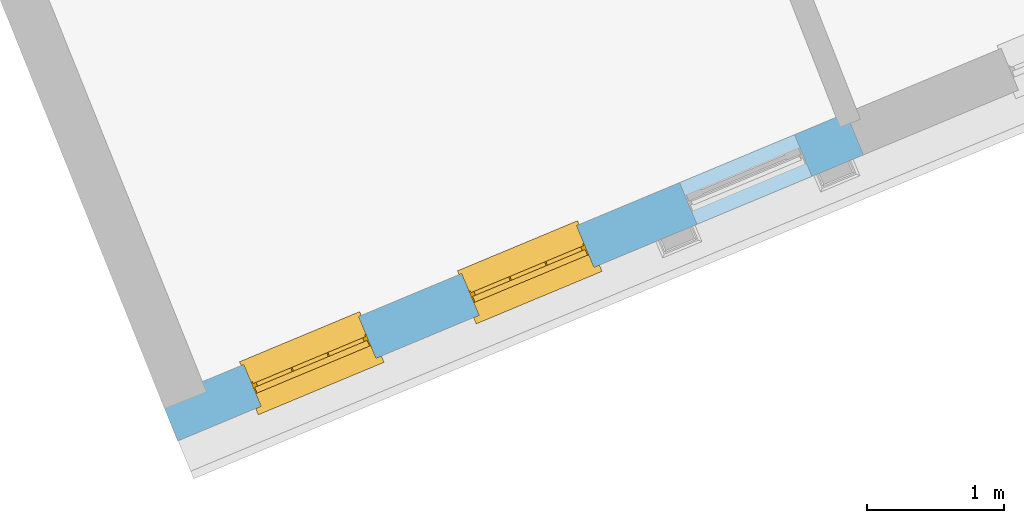
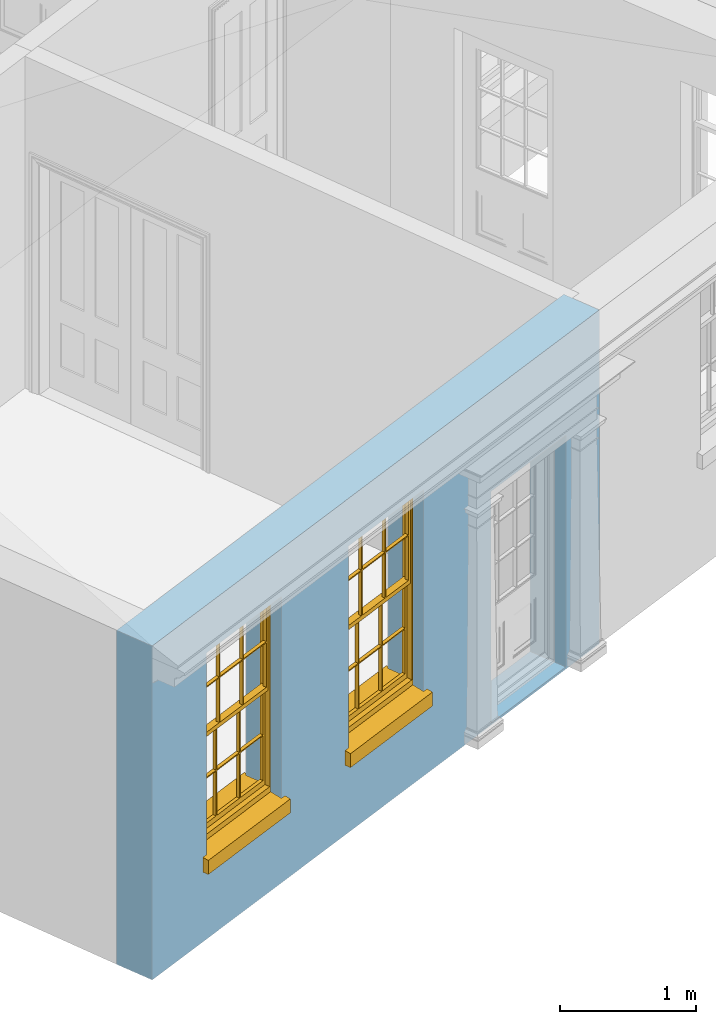
# One storey, part 3 of 19: 2 windows, 3 openings, plus 1 element that does not belong to this part.
"""IFC2X3 building model written with IfcOpenShell, lengths in metres."""

from ifc_helpers import new_model, si_unit, frame, origin, place, context, subcontext, project, spatial, polyline, outline, extrude, faceted_brep, material, layer, layer_set, layer_usage, element, fill, save


model = new_model("IFC2X3")

# Units and contexts
model_context = context("Model", 3, world=origin())
body_context = subcontext(model_context, "Body", "Model", "MODEL_VIEW")
ifc_project = project(units=[si_unit("PLANEANGLEUNIT", "RADIAN"), si_unit("MASSUNIT", "GRAM", prefix="KILO"), si_unit("FORCEUNIT", "NEWTON", prefix="KILO"), si_unit("LENGTHUNIT", "METRE")], contexts=[model_context])

# Site, building, storey
site_placement = place(None, origin())
site = spatial("IfcSite", under=ifc_project, at=site_placement, CompositionType="ELEMENT")
building_placement = place(None, origin())
building = spatial("IfcBuilding", under=site, at=building_placement, Name="Building plot-0", CompositionType="ELEMENT")
storey_placement = place(None, origin())
storey = spatial("IfcBuildingStorey", under=building, at=storey_placement, Name="Floor 0", CompositionType="ELEMENT", Elevation=0.0)

# Wall, openings, windows
ifc_material = material(Name="Masonry")
ifc_layer = layer(ifc_material, 0.33, ventilated=False)
ifc_layer_set = layer_set([ifc_layer], Name="My Wall")
ifc_layer_usage = layer_usage(ifc_layer_set, "AXIS2", "NEGATIVE", 0.08)
wall_placement = place(storey_placement, origin())
wall = element("IfcWallStandardCase", 1, at=wall_placement, inside=storey, material=ifc_layer_usage, Name="exterior", context=body_context, shape_type="SweptSolid", body=[
    extrude(outline(polyline([(16.1700267177394, 20.5032297368677), (16.2971036159413, 20.1986784900415), (21.3007494176732, 22.2864971898878), (21.1736725194713, 22.591048436714), (16.1700267177394, 20.5032297368677)])), origin(), (0.0, 0.0, 1.0), 3.0),
])
opening_1_placement = place(storey_placement, frame((0.0, 0.0, 0.75)))
opening_1 = element("IfcOpeningElement", 2, at=opening_1_placement, cuts=wall, Name="Opening", ObjectType="Opening", context=body_context, shape_type="SweptSolid", body=[
    extrude(outline(polyline([(16.9034002165821, 20.4516615009559), (17.7432233517695, 20.8020856747854), (17.6161464535675, 21.1066369216116), (16.7763233183802, 20.756212747782), (16.9034002165821, 20.4516615009559)])), origin(), (0.0, 0.0, 1.0), 1.82),
])
opening_2_placement = place(storey_placement, frame((0.0, 0.0, 0.75)))
opening_2 = element("IfcOpeningElement", 3, at=opening_2_placement, cuts=wall, Name="Opening", ObjectType="Opening", context=body_context, shape_type="SweptSolid", body=[
    extrude(outline(polyline([(18.4943752699811, 21.1155109417627), (19.3341984051684, 21.4659351155923), (19.2071215069665, 21.7704863624185), (18.3672983717792, 21.4200621885889), (18.4943752699811, 21.1155109417627)])), origin(), (0.0, 0.0, 1.0), 1.82),
])
opening_3_placement = place(storey_placement, frame((0.0, 0.0, 0.02)))
element("IfcOpeningElement", 4, at=opening_3_placement, cuts=wall, Name="Opening", ObjectType="Opening", context=body_context, shape_type="SweptSolid", body=[
    extrude(outline(polyline([(20.0853503233801, 21.7793603825696), (20.9251734585674, 22.1297845563992), (20.7980965603655, 22.4343358032253), (19.9582734251781, 22.0839116293958), (20.0853503233801, 21.7793603825696)])), origin(), (0.0, 0.0, 1.0), 2.08),
])
window_1_placement = place(storey_placement, frame((16.8071298391564, 20.6823821424909, 0.75), z_axis=(0.0, 0.0, 1.0), x_axis=(0.839823135187327, 0.350424173829563, 0.0)))
window_1 = element("IfcWindow", 5, at=window_1_placement, inside=storey, Name="living street window", OverallHeight=1.82, OverallWidth=0.91, context=body_context, shape_type="Brep", held_by="IfcProductRepresentation", body=[
    faceted_brep([(0.033125, -0.105, 0.975209), (0.01, -0.105, 0.975209), (0.033125, -0.105, 1.376042), (0.876875, -0.105, 0.975209), (0.876875, -0.105, 1.376042), (0.9, -0.105, 0.975209), (0.876875, -0.105, 1.386042), (0.876875, -0.105, 1.786875), (0.9, -0.105, 1.81), (0.033125, -0.105, 1.786875), (0.033125, -0.105, 1.386042), (0.01, -0.105, 1.81), (0.876875, -0.135, 1.376042), (0.876875, -0.135, 0.975209), (0.9, -0.135, 0.937083), (0.033125, -0.135, 1.786875), (0.01, -0.135, 1.81), (0.033125, -0.135, 1.386042), (0.01, -0.135, 0.937083), (0.033125, -0.135, 0.975209), (0.033125, -0.135, 1.376042), (0.876875, -0.135, 1.786875), (0.876875, -0.135, 1.386042), (0.9, -0.135, 1.81), (0.033125, -0.105, 0.937083), (0.01, -0.105, 0.937083), (0.033125, -0.105, 0.53625), (0.876875, -0.105, 0.937083), (0.876875, -0.105, 0.53625), (0.9, -0.105, 0.937083), (0.876875, -0.105, 0.52625), (0.876875, -0.105, 0.125417), (0.9, -0.105, 0.077167), (0.033125, -0.105, 0.125417), (0.033125, -0.105, 0.52625), (0.01, -0.105, 0.077167), (-0.0425, -0.25, 0.01), (-0.0425, -0.3, 0.001667), (0.0, -0.25, 0.01), (0.9525, -0.25, 0.01), (0.91, -0.25, 0.01), (0.9525, -0.3, 0.001667), (-0.02, 0.08, 0.077167), (0.0, 0.08, 0.077167), (-0.02, 0.11, 0.077167), (0.0, -0.06, 0.077167), (0.01, -0.06, 0.077167), (0.91, -0.06, 0.077167), (0.91, 0.08, 0.077167), (0.9, -0.06, 0.077167), (0.93, 0.08, 0.077167), (0.93, 0.11, 0.077167), (0.01, -0.075, 0.975209), (0.9, -0.075, 0.975209), (0.876875, -0.075, 0.125417), (0.876875, -0.075, 0.52625), (0.9, -0.075, 0.077167), (0.876875, -0.075, 0.53625), (0.876875, -0.075, 0.937083), (0.033125, -0.075, 0.125417), (0.01, -0.075, 0.077167), (0.033125, -0.075, 0.52625), (0.033125, -0.075, 0.937083), (0.033125, -0.075, 0.53625), (-0.02, 0.08, 0.052167), (-0.02, 0.11, 0.052167), (0.93, 0.11, 0.052167), (0.93, 0.08, 0.052167), (0.91, 0.08, 0.052167), (0.0, 0.08, 0.052167), (0.91, -0.15, 0.026667), (0.0, -0.15, 0.026667), (-0.0425, -0.3, -0.123333), (0.9525, -0.3, -0.123333), (-0.0425, -0.25, -0.123333), (0.9525, -0.25, -0.123333), (0.01, -0.06, 1.81), (0.9, -0.06, 1.81), (0.0, -0.06, 1.82), (0.91, -0.06, 1.82), (0.01, -0.15, 0.077167), (0.9, -0.15, 0.077167), (0.592292, -0.105, 0.125417), (0.592292, -0.075, 0.125417), (0.317708, -0.075, 0.125417), (0.317708, -0.105, 0.125417), (0.592292, -0.105, 0.53625), (0.317708, -0.105, 0.53625), (0.317708, -0.105, 0.52625), (0.592292, -0.105, 0.52625), (0.592292, -0.075, 0.53625), (0.317708, -0.075, 0.53625), (0.592292, -0.135, 1.386042), (0.592292, -0.105, 1.386042), (0.317708, -0.105, 1.386042), (0.317708, -0.135, 1.386042), (0.317708, -0.135, 1.376042), (0.592292, -0.135, 1.376042), (0.317708, -0.105, 1.376042), (0.592292, -0.105, 1.376042), (0.602292, -0.135, 1.376042), (0.592292, -0.135, 0.975209), (0.602292, -0.135, 0.975209), (0.602292, -0.105, 0.975209), (0.592292, -0.105, 0.975209), (0.602292, -0.105, 1.376042), (0.602292, -0.075, 0.53625), (0.602292, -0.105, 0.53625), (0.317708, -0.075, 0.52625), (0.307708, -0.075, 0.125417), (0.307708, -0.075, 0.52625), (0.602292, -0.075, 0.52625), (0.602292, -0.075, 0.125417), (0.592292, -0.075, 0.52625), (0.307708, -0.075, 0.53625), (0.317708, -0.075, 0.937083), (0.307708, -0.075, 0.937083), (0.602292, -0.075, 0.937083), (0.592292, -0.075, 0.937083), (0.307708, -0.105, 0.52625), (0.307708, -0.105, 0.125417), (0.307708, -0.105, 0.53625), (0.307708, -0.105, 0.937083), (0.592292, -0.105, 0.937083), (0.317708, -0.105, 0.937083), (0.602292, -0.105, 0.937083), (0.602292, -0.105, 0.52625), (0.602292, -0.105, 0.125417), (0.307708, -0.135, 1.386042), (0.307708, -0.135, 1.376042), (0.307708, -0.135, 0.975209), (0.317708, -0.135, 0.975209), (0.317708, -0.135, 1.786875), (0.307708, -0.135, 1.786875), (0.602292, -0.135, 1.786875), (0.592292, -0.135, 1.786875), (0.602292, -0.135, 1.386042), (0.602292, -0.105, 1.386042), (0.307708, -0.105, 1.386042), (0.307708, -0.105, 1.786875), (0.317708, -0.105, 1.786875), (0.592292, -0.105, 1.786875), (0.602292, -0.105, 1.786875), (0.307708, -0.105, 1.376042), (0.317708, -0.105, 0.975209), (0.307708, -0.105, 0.975209), (0.91, -0.15, 1.82), (0.9, -0.15, 1.81), (0.01, -0.15, 1.81), (0.0, -0.15, 1.82), (0.91, -0.25, 0.0), (0.0, -0.25, 0.0), (0.91, 0.08, 0.0), (0.0, 0.08, 0.0)], [[[0, 1, 2]], [[3, 4, 5]], [[6, 7, 8]], [[9, 10, 11]], [[12, 13, 14]], [[15, 16, 17]], [[18, 19, 20]], [[21, 22, 23]], [[24, 25, 26]], [[27, 28, 29]], [[30, 31, 32]], [[33, 34, 35]], [[14, 27, 29]], [[25, 24, 18]], [[36, 37, 38]], [[39, 40, 41]], [[42, 43, 44]], [[45, 46, 43]], [[47, 48, 49]], [[50, 51, 48]], [[1, 0, 52]], [[5, 53, 3]], [[54, 55, 56]], [[57, 58, 53]], [[59, 60, 61]], [[62, 63, 52]], [[48, 43, 46, 49]], [[51, 44, 43, 48]], [[64, 42, 44, 65]], [[65, 44, 51, 66]], [[66, 51, 50, 67]], [[65, 66, 68, 69]], [[60, 56, 49, 46]], [[70, 71, 38, 40]], [[37, 41, 40, 38]], [[37, 72, 73, 41]], [[74, 75, 73, 72]], [[8, 11, 76, 77]], [[76, 78, 79, 77]], [[32, 35, 80, 81]], [[81, 80, 71, 70]], [[82, 83, 84, 85]], [[86, 87, 88, 89]], [[86, 90, 91, 87]], [[92, 93, 94, 95]], [[92, 95, 96, 97]], [[96, 98, 99, 97]], [[100, 97, 101, 102]], [[103, 104, 99, 105]], [[97, 99, 104, 101]], [[102, 103, 105, 100]], [[28, 57, 106, 107]], [[108, 84, 109, 110]], [[111, 112, 83, 113]], [[114, 110, 61, 63]], [[90, 113, 108, 91]], [[115, 91, 114, 116]], [[117, 106, 90, 118]], [[111, 106, 57, 55]], [[119, 110, 109, 120]], [[34, 61, 110, 119]], [[89, 113, 83, 82]], [[88, 108, 113, 89]], [[85, 84, 108, 88]], [[121, 114, 63, 26]], [[122, 116, 114, 121]], [[123, 118, 90, 86]], [[87, 91, 115, 124]], [[107, 106, 117, 125]], [[126, 111, 55, 30]], [[127, 112, 111, 126]], [[126, 30, 28, 107]], [[88, 119, 120, 85]], [[126, 89, 82, 127]], [[125, 123, 86, 107]], [[121, 26, 34, 119]], [[124, 122, 121, 87]], [[128, 17, 20, 129]], [[96, 129, 130, 131]], [[132, 133, 128, 95]], [[134, 135, 92, 136]], [[100, 12, 22, 136]], [[137, 6, 4, 105]], [[94, 138, 139, 140]], [[137, 93, 141, 142]], [[99, 98, 94, 93]], [[143, 2, 10, 138]], [[144, 145, 143, 98]], [[129, 143, 145, 130]], [[20, 2, 143, 129]], [[131, 144, 98, 96]], [[128, 138, 10, 17]], [[133, 139, 138, 128]], [[135, 141, 93, 92]], [[95, 94, 140, 132]], [[22, 6, 137, 136]], [[136, 137, 142, 134]], [[100, 105, 4, 12]], [[107, 86, 89, 126]], [[106, 111, 113, 90]], [[91, 108, 110, 114]], [[87, 121, 119, 88]], [[97, 100, 136, 92]], [[129, 96, 95, 128]], [[98, 143, 138, 94]], [[105, 99, 93, 137]], [[131, 101, 104, 144]], [[124, 115, 118, 123]], [[132, 140, 141, 135]], [[120, 109, 59, 33]], [[15, 9, 139, 133]], [[134, 142, 7, 21]], [[31, 54, 112, 127]], [[36, 74, 72, 37]], [[39, 41, 73, 75]], [[18, 14, 101, 131]], [[23, 16, 132, 135]], [[83, 56, 60, 84]], [[52, 53, 118, 115]], [[53, 52, 144, 104]], [[11, 8, 141, 140]], [[14, 18, 124, 123]], [[2, 1, 11, 10]], [[8, 5, 4, 6]], [[57, 53, 56, 55]], [[60, 52, 63, 61]], [[26, 25, 35, 34]], [[32, 29, 28, 30]], [[14, 23, 22, 12]], [[18, 20, 17, 16]], [[19, 0, 2, 20]], [[17, 10, 9, 15]], [[12, 4, 3, 13]], [[21, 7, 6, 22]], [[27, 58, 57, 28]], [[30, 55, 54, 31]], [[33, 59, 61, 34]], [[26, 63, 62, 24]], [[5, 8, 77, 53]], [[76, 11, 1, 52]], [[46, 45, 78, 76]], [[49, 77, 79, 47]], [[70, 146, 147, 81]], [[71, 80, 148, 149]], [[19, 130, 145, 0]], [[102, 13, 3, 103]], [[116, 122, 24, 62]], [[29, 32, 81, 14]], [[80, 35, 25, 18]], [[60, 46, 76, 52]], [[77, 49, 56, 53]], [[23, 14, 81, 147]], [[16, 148, 80, 18]], [[35, 85, 120]], [[120, 33, 35]], [[127, 82, 32]], [[32, 31, 127]], [[32, 82, 85, 35]], [[102, 101, 14]], [[14, 13, 102]], [[18, 131, 130]], [[130, 19, 18]], [[134, 21, 23]], [[23, 135, 134]], [[16, 15, 133]], [[133, 132, 16]], [[11, 140, 139]], [[139, 9, 11]], [[142, 141, 8]], [[8, 7, 142]], [[23, 147, 148, 16]], [[146, 149, 148, 147]], [[52, 115, 116]], [[116, 62, 52]], [[118, 53, 117]], [[58, 117, 53]], [[27, 125, 117, 58]], [[56, 83, 112]], [[112, 54, 56]], [[109, 84, 60]], [[60, 59, 109]], [[125, 27, 14]], [[14, 123, 125]], [[122, 124, 18]], [[18, 24, 122]], [[145, 144, 52]], [[52, 0, 145]], [[103, 3, 53]], [[53, 104, 103]], [[79, 78, 149, 146]], [[78, 45, 71, 149]], [[146, 70, 47, 79]], [[150, 75, 74, 151]], [[68, 66, 67]], [[48, 68, 67, 50]], [[69, 64, 65]], [[42, 64, 69, 43]], [[69, 68, 152, 153]], [[70, 68, 48, 47]], [[150, 152, 68, 70]], [[43, 69, 71, 45]], [[69, 153, 151, 71]], [[152, 150, 151, 153]], [[38, 151, 74, 36]], [[71, 151, 38]], [[39, 75, 150, 40]], [[40, 150, 70]]]),
])
fill(opening_1, window_1)
window_2_placement = place(storey_placement, frame((18.3981048925554, 21.3462315832977, 0.75), z_axis=(0.0, 0.0, 1.0), x_axis=(0.839823135187324, 0.350424173829563, 0.0)))
window_2 = element("IfcWindow", 6, at=window_2_placement, inside=storey, Name="living street window", OverallHeight=1.82, OverallWidth=0.91, context=body_context, shape_type="Brep", held_by="IfcProductRepresentation", body=[
    faceted_brep([(0.033125, -0.105, 0.975209), (0.01, -0.105, 0.975209), (0.033125, -0.105, 1.376042), (0.876875, -0.105, 0.975209), (0.876875, -0.105, 1.376042), (0.9, -0.105, 0.975209), (0.876875, -0.105, 1.386042), (0.876875, -0.105, 1.786875), (0.9, -0.105, 1.81), (0.033125, -0.105, 1.786875), (0.033125, -0.105, 1.386042), (0.01, -0.105, 1.81), (0.876875, -0.135, 1.376042), (0.876875, -0.135, 0.975209), (0.9, -0.135, 0.937083), (0.033125, -0.135, 1.786875), (0.01, -0.135, 1.81), (0.033125, -0.135, 1.386042), (0.01, -0.135, 0.937083), (0.033125, -0.135, 0.975209), (0.033125, -0.135, 1.376042), (0.876875, -0.135, 1.786875), (0.876875, -0.135, 1.386042), (0.9, -0.135, 1.81), (0.033125, -0.105, 0.937083), (0.01, -0.105, 0.937083), (0.033125, -0.105, 0.53625), (0.876875, -0.105, 0.937083), (0.876875, -0.105, 0.53625), (0.9, -0.105, 0.937083), (0.876875, -0.105, 0.52625), (0.876875, -0.105, 0.125417), (0.9, -0.105, 0.077167), (0.033125, -0.105, 0.125417), (0.033125, -0.105, 0.52625), (0.01, -0.105, 0.077167), (-0.0425, -0.25, 0.01), (-0.0425, -0.3, 0.001667), (0.0, -0.25, 0.01), (0.9525, -0.25, 0.01), (0.91, -0.25, 0.01), (0.9525, -0.3, 0.001667), (-0.02, 0.08, 0.077167), (0.0, 0.08, 0.077167), (-0.02, 0.11, 0.077167), (0.0, -0.06, 0.077167), (0.01, -0.06, 0.077167), (0.91, -0.06, 0.077167), (0.91, 0.08, 0.077167), (0.9, -0.06, 0.077167), (0.93, 0.08, 0.077167), (0.93, 0.11, 0.077167), (0.01, -0.075, 0.975209), (0.9, -0.075, 0.975209), (0.876875, -0.075, 0.125417), (0.876875, -0.075, 0.52625), (0.9, -0.075, 0.077167), (0.876875, -0.075, 0.53625), (0.876875, -0.075, 0.937083), (0.033125, -0.075, 0.125417), (0.01, -0.075, 0.077167), (0.033125, -0.075, 0.52625), (0.033125, -0.075, 0.937083), (0.033125, -0.075, 0.53625), (-0.02, 0.08, 0.052167), (-0.02, 0.11, 0.052167), (0.93, 0.11, 0.052167), (0.93, 0.08, 0.052167), (0.91, 0.08, 0.052167), (0.0, 0.08, 0.052167), (0.91, -0.15, 0.026667), (0.0, -0.15, 0.026667), (-0.0425, -0.3, -0.123333), (0.9525, -0.3, -0.123333), (-0.0425, -0.25, -0.123333), (0.9525, -0.25, -0.123333), (0.01, -0.06, 1.81), (0.9, -0.06, 1.81), (0.0, -0.06, 1.82), (0.91, -0.06, 1.82), (0.01, -0.15, 0.077167), (0.9, -0.15, 0.077167), (0.592292, -0.105, 0.125417), (0.592292, -0.075, 0.125417), (0.317708, -0.075, 0.125417), (0.317708, -0.105, 0.125417), (0.592292, -0.105, 0.53625), (0.317708, -0.105, 0.53625), (0.317708, -0.105, 0.52625), (0.592292, -0.105, 0.52625), (0.592292, -0.075, 0.53625), (0.317708, -0.075, 0.53625), (0.592292, -0.135, 1.386042), (0.592292, -0.105, 1.386042), (0.317708, -0.105, 1.386042), (0.317708, -0.135, 1.386042), (0.317708, -0.135, 1.376042), (0.592292, -0.135, 1.376042), (0.317708, -0.105, 1.376042), (0.592292, -0.105, 1.376042), (0.602292, -0.135, 1.376042), (0.592292, -0.135, 0.975209), (0.602292, -0.135, 0.975209), (0.602292, -0.105, 0.975209), (0.592292, -0.105, 0.975209), (0.602292, -0.105, 1.376042), (0.602292, -0.075, 0.53625), (0.602292, -0.105, 0.53625), (0.317708, -0.075, 0.52625), (0.307708, -0.075, 0.125417), (0.307708, -0.075, 0.52625), (0.602292, -0.075, 0.52625), (0.602292, -0.075, 0.125417), (0.592292, -0.075, 0.52625), (0.307708, -0.075, 0.53625), (0.317708, -0.075, 0.937083), (0.307708, -0.075, 0.937083), (0.602292, -0.075, 0.937083), (0.592292, -0.075, 0.937083), (0.307708, -0.105, 0.52625), (0.307708, -0.105, 0.125417), (0.307708, -0.105, 0.53625), (0.307708, -0.105, 0.937083), (0.592292, -0.105, 0.937083), (0.317708, -0.105, 0.937083), (0.602292, -0.105, 0.937083), (0.602292, -0.105, 0.52625), (0.602292, -0.105, 0.125417), (0.307708, -0.135, 1.386042), (0.307708, -0.135, 1.376042), (0.307708, -0.135, 0.975209), (0.317708, -0.135, 0.975209), (0.317708, -0.135, 1.786875), (0.307708, -0.135, 1.786875), (0.602292, -0.135, 1.786875), (0.592292, -0.135, 1.786875), (0.602292, -0.135, 1.386042), (0.602292, -0.105, 1.386042), (0.307708, -0.105, 1.386042), (0.307708, -0.105, 1.786875), (0.317708, -0.105, 1.786875), (0.592292, -0.105, 1.786875), (0.602292, -0.105, 1.786875), (0.307708, -0.105, 1.376042), (0.317708, -0.105, 0.975209), (0.307708, -0.105, 0.975209), (0.91, -0.15, 1.82), (0.9, -0.15, 1.81), (0.01, -0.15, 1.81), (0.0, -0.15, 1.82), (0.91, -0.25, 0.0), (0.0, -0.25, 0.0), (0.91, 0.08, 0.0), (0.0, 0.08, 0.0)], [[[0, 1, 2]], [[3, 4, 5]], [[6, 7, 8]], [[9, 10, 11]], [[12, 13, 14]], [[15, 16, 17]], [[18, 19, 20]], [[21, 22, 23]], [[24, 25, 26]], [[27, 28, 29]], [[30, 31, 32]], [[33, 34, 35]], [[14, 27, 29]], [[25, 24, 18]], [[36, 37, 38]], [[39, 40, 41]], [[42, 43, 44]], [[45, 46, 43]], [[47, 48, 49]], [[50, 51, 48]], [[1, 0, 52]], [[5, 53, 3]], [[54, 55, 56]], [[57, 58, 53]], [[59, 60, 61]], [[62, 63, 52]], [[48, 43, 46, 49]], [[51, 44, 43, 48]], [[64, 42, 44, 65]], [[65, 44, 51, 66]], [[66, 51, 50, 67]], [[65, 66, 68, 69]], [[60, 56, 49, 46]], [[70, 71, 38, 40]], [[37, 41, 40, 38]], [[37, 72, 73, 41]], [[74, 75, 73, 72]], [[8, 11, 76, 77]], [[76, 78, 79, 77]], [[32, 35, 80, 81]], [[81, 80, 71, 70]], [[82, 83, 84, 85]], [[86, 87, 88, 89]], [[86, 90, 91, 87]], [[92, 93, 94, 95]], [[92, 95, 96, 97]], [[96, 98, 99, 97]], [[100, 97, 101, 102]], [[103, 104, 99, 105]], [[97, 99, 104, 101]], [[102, 103, 105, 100]], [[28, 57, 106, 107]], [[108, 84, 109, 110]], [[111, 112, 83, 113]], [[114, 110, 61, 63]], [[90, 113, 108, 91]], [[115, 91, 114, 116]], [[117, 106, 90, 118]], [[111, 106, 57, 55]], [[119, 110, 109, 120]], [[34, 61, 110, 119]], [[89, 113, 83, 82]], [[88, 108, 113, 89]], [[85, 84, 108, 88]], [[121, 114, 63, 26]], [[122, 116, 114, 121]], [[123, 118, 90, 86]], [[87, 91, 115, 124]], [[107, 106, 117, 125]], [[126, 111, 55, 30]], [[127, 112, 111, 126]], [[126, 30, 28, 107]], [[88, 119, 120, 85]], [[126, 89, 82, 127]], [[125, 123, 86, 107]], [[121, 26, 34, 119]], [[124, 122, 121, 87]], [[128, 17, 20, 129]], [[96, 129, 130, 131]], [[132, 133, 128, 95]], [[134, 135, 92, 136]], [[100, 12, 22, 136]], [[137, 6, 4, 105]], [[94, 138, 139, 140]], [[137, 93, 141, 142]], [[99, 98, 94, 93]], [[143, 2, 10, 138]], [[144, 145, 143, 98]], [[129, 143, 145, 130]], [[20, 2, 143, 129]], [[131, 144, 98, 96]], [[128, 138, 10, 17]], [[133, 139, 138, 128]], [[135, 141, 93, 92]], [[95, 94, 140, 132]], [[22, 6, 137, 136]], [[136, 137, 142, 134]], [[100, 105, 4, 12]], [[107, 86, 89, 126]], [[106, 111, 113, 90]], [[91, 108, 110, 114]], [[87, 121, 119, 88]], [[97, 100, 136, 92]], [[129, 96, 95, 128]], [[98, 143, 138, 94]], [[105, 99, 93, 137]], [[131, 101, 104, 144]], [[124, 115, 118, 123]], [[132, 140, 141, 135]], [[120, 109, 59, 33]], [[15, 9, 139, 133]], [[134, 142, 7, 21]], [[31, 54, 112, 127]], [[36, 74, 72, 37]], [[39, 41, 73, 75]], [[18, 14, 101, 131]], [[23, 16, 132, 135]], [[83, 56, 60, 84]], [[52, 53, 118, 115]], [[53, 52, 144, 104]], [[11, 8, 141, 140]], [[14, 18, 124, 123]], [[2, 1, 11, 10]], [[8, 5, 4, 6]], [[57, 53, 56, 55]], [[60, 52, 63, 61]], [[26, 25, 35, 34]], [[32, 29, 28, 30]], [[14, 23, 22, 12]], [[18, 20, 17, 16]], [[19, 0, 2, 20]], [[17, 10, 9, 15]], [[12, 4, 3, 13]], [[21, 7, 6, 22]], [[27, 58, 57, 28]], [[30, 55, 54, 31]], [[33, 59, 61, 34]], [[26, 63, 62, 24]], [[5, 8, 77, 53]], [[76, 11, 1, 52]], [[46, 45, 78, 76]], [[49, 77, 79, 47]], [[70, 146, 147, 81]], [[71, 80, 148, 149]], [[19, 130, 145, 0]], [[102, 13, 3, 103]], [[116, 122, 24, 62]], [[29, 32, 81, 14]], [[80, 35, 25, 18]], [[60, 46, 76, 52]], [[77, 49, 56, 53]], [[23, 14, 81, 147]], [[16, 148, 80, 18]], [[35, 85, 120]], [[120, 33, 35]], [[127, 82, 32]], [[32, 31, 127]], [[32, 82, 85, 35]], [[102, 101, 14]], [[14, 13, 102]], [[18, 131, 130]], [[130, 19, 18]], [[134, 21, 23]], [[23, 135, 134]], [[16, 15, 133]], [[133, 132, 16]], [[11, 140, 139]], [[139, 9, 11]], [[142, 141, 8]], [[8, 7, 142]], [[23, 147, 148, 16]], [[146, 149, 148, 147]], [[52, 115, 116]], [[116, 62, 52]], [[118, 53, 117]], [[58, 117, 53]], [[27, 125, 117, 58]], [[56, 83, 112]], [[112, 54, 56]], [[109, 84, 60]], [[60, 59, 109]], [[125, 27, 14]], [[14, 123, 125]], [[122, 124, 18]], [[18, 24, 122]], [[145, 144, 52]], [[52, 0, 145]], [[103, 3, 53]], [[53, 104, 103]], [[79, 78, 149, 146]], [[78, 45, 71, 149]], [[146, 70, 47, 79]], [[150, 75, 74, 151]], [[68, 66, 67]], [[48, 68, 67, 50]], [[69, 64, 65]], [[42, 64, 69, 43]], [[69, 68, 152, 153]], [[70, 68, 48, 47]], [[150, 152, 68, 70]], [[43, 69, 71, 45]], [[69, 153, 151, 71]], [[152, 150, 151, 153]], [[38, 151, 74, 36]], [[71, 151, 38]], [[39, 75, 150, 40]], [[40, 150, 70]]]),
])
fill(opening_2, window_2)

save(model, "model.ifc")
